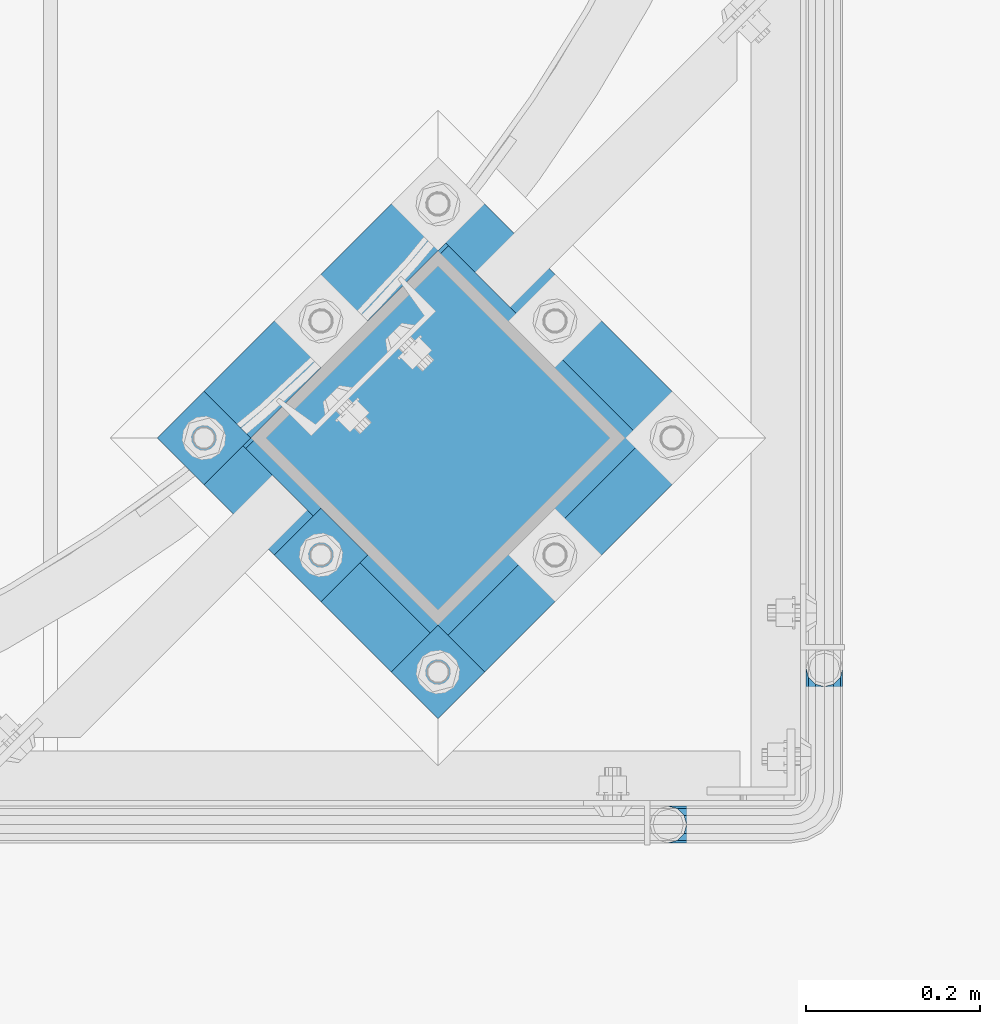
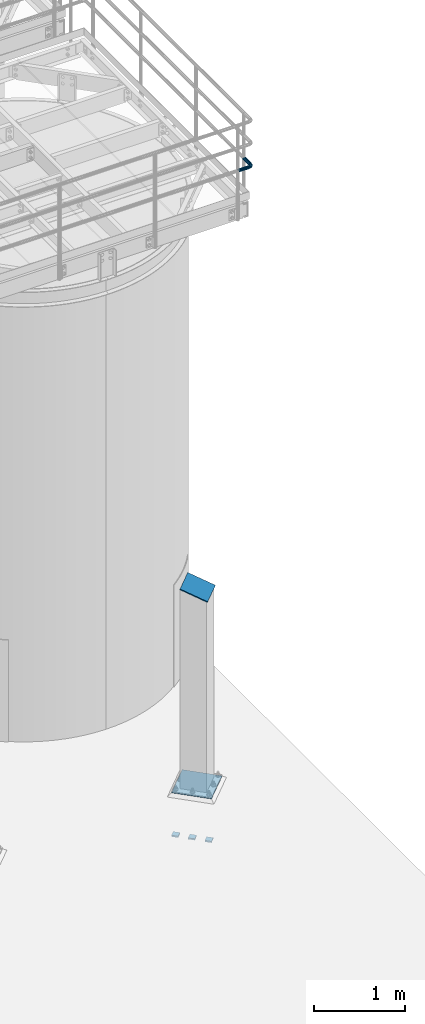
# One storey, part 1101 of 1876: 5 beams, 1 member, 3 elements without a shape of their own.
"""IFC2X3 building model written with IfcOpenShell, lengths in millimetres."""

import ifcopenshell
import ifcopenshell.guid

model = None  # the IFC model being written
_history = None  # IfcOwnerHistory: only IFC2X3 demands one
_inside = {}  # id of a spatial element -> (the spatial element, [elements in it])
_under = {}  # id of a project, library or spatial element -> (it, [spatial elements below it])
_declared = {}  # id of a project -> (the project, [libraries it declares])
_typed = {}  # id of a type object -> (the type object, [elements of that type])
_made_of = {}  # id of a material, layer set ... -> (it, [elements and type objects made of it])


def new_model(schema):
    """Start an empty IFC model of exactly this schema.

    Asked for "IFC4X3", IfcOpenShell would pick the latest addendum, in which some entities
    have other attributes; the version numbers below select the first issue.
    IFC2X3 requires an IfcOwnerHistory on every rooted entity: one is made here for all.
    """
    global model, _history
    if schema == "IFC4X3":
        model = ifcopenshell.file(schema_version=(4, 3, 0, 0))
    else:
        model = ifcopenshell.file(schema=schema)
    _inside.clear()
    _under.clear()
    _declared.clear()
    _typed.clear()
    _made_of.clear()
    _history = None
    if model.schema == "IFC2X3":
        org = make("IfcOrganization", Name="unknown")
        user = make(
            "IfcPersonAndOrganization",
            ThePerson=make("IfcPerson", FamilyName="unknown"),
            TheOrganization=org,
        )
        app = make(
            "IfcApplication",
            ApplicationDeveloper=org,
            Version="unknown",
            ApplicationFullName="unknown",
            ApplicationIdentifier="unknown",
        )
        _history = make(
            "IfcOwnerHistory",
            OwningUser=user,
            OwningApplication=app,
            ChangeAction="ADDED",
            CreationDate=0,
        )
    return model


def make(cls, **values):
    """One entity of the class cls with the attributes given. An attribute that is None is left unset."""
    return model.create_entity(
        cls, **{name: value for name, value in values.items() if value is not None}
    )


def rooted(cls, **values):
    """An entity with a GlobalId (a new one), such as an element, a storey or a relation."""
    return make(cls, GlobalId=ifcopenshell.guid.new(), OwnerHistory=_history, **values)


def si_unit(unit_type, name, prefix=None):
    """IfcSIUnit, for example si_unit("LENGTHUNIT", "METRE", prefix="MILLI")."""
    return make("IfcSIUnit", UnitType=unit_type, Prefix=prefix, Name=name)


def assignment(units):
    """IfcUnitAssignment: the units of a project."""
    return None if units is None else make("IfcUnitAssignment", Units=units)


def point(xyz):
    """IfcCartesianPoint."""
    return None if xyz is None else make("IfcCartesianPoint", Coordinates=xyz)


def direction(xyz):
    """IfcDirection."""
    return None if xyz is None else make("IfcDirection", DirectionRatios=xyz)


def frame(location, z_axis=None, x_axis=None):
    """IfcAxis2Placement3D, a coordinate frame: its origin and axes. An axis left out is left unset."""
    return make(
        "IfcAxis2Placement3D",
        Location=point(location),
        Axis=direction(z_axis),
        RefDirection=direction(x_axis),
    )


def origin_with_axes():
    """The frame at (0, 0, 0) with the z axis (0, 0, 1) and the x axis (1, 0, 0) written out."""
    return frame((0.0, 0.0, 0.0), z_axis=(0.0, 0.0, 1.0), x_axis=(1.0, 0.0, 0.0))


def place(relative_to, where):
    """IfcLocalPlacement: puts the frame where relative to a parent placement (None: the world)."""
    return make(
        "IfcLocalPlacement", PlacementRelTo=relative_to, RelativePlacement=where
    )


def context(
    kind, dimensions, precision=None, world=None, true_north=None, identifier=None
):
    """IfcGeometricRepresentationContext, for example the 3D "Model" context."""
    return make(
        "IfcGeometricRepresentationContext",
        ContextIdentifier=identifier,
        ContextType=kind,
        CoordinateSpaceDimension=dimensions,
        Precision=precision,
        WorldCoordinateSystem=world,
        TrueNorth=true_north,
    )


def subcontext(parent, identifier, kind, view, scale=None):
    """IfcGeometricRepresentationSubContext, for example "Body" below "Model"."""
    return make(
        "IfcGeometricRepresentationSubContext",
        ContextIdentifier=identifier,
        ContextType=kind,
        ParentContext=parent,
        TargetScale=scale,
        TargetView=view,
    )


def project(units=None, contexts=None):
    """IfcProject with its units and contexts."""
    return rooted(
        "IfcProject",
        Name="project",
        RepresentationContexts=contexts,
        UnitsInContext=assignment(units),
    )


def spatial(cls, under=None, at=None, **own):
    """A site, building, storey or space (cls), placed at a placement, below another one or the project."""
    s = rooted(cls, ObjectPlacement=at, **own)
    if under is not None:
        _under.setdefault(under.id(), (under, []))[1].append(s)
    return s


def faces_of(points, faces, orient=None, outer=None):
    """IfcFace entities. A face is a list of loops; a loop is a list of indices into points, from 0.

    orient and outer hold one flag for each loop. By default every Orientation is true, the
    first loop of a face is its IfcFaceOuterBound and the others are IfcFaceBound.
    """
    made = []
    for i, loops in enumerate(faces):
        bounds = []
        for j, loop in enumerate(loops):
            is_outer = j == 0 if outer is None else outer[i][j]
            bounds.append(
                make(
                    "IfcFaceOuterBound" if is_outer else "IfcFaceBound",
                    Bound=make("IfcPolyLoop", Polygon=[points[k] for k in loop]),
                    Orientation=True if orient is None else orient[i][j],
                )
            )
        made.append(make("IfcFace", Bounds=bounds))
    return made


def faceted_brep(points, faces, orient=None, outer=None, voids=None):
    """IfcFacetedBrep: a solid bounded by flat faces; with voids (closed shells), ...WithVoids."""
    shared = [point(p) for p in points]
    hull = make("IfcClosedShell", CfsFaces=faces_of(shared, faces, orient, outer))
    if voids is None:
        return make("IfcFacetedBrep", Outer=hull)
    return make(
        "IfcFacetedBrepWithVoids",
        Outer=hull,
        Voids=[
            make(cls, CfsFaces=faces_of(shared, fs, o, b)) for cls, fs, o, b in voids
        ],
    )


def shape(context_of_items, identifier, shape_type, items):
    """IfcShapeRepresentation: the items that make up one representation, for example the "Body"."""
    return make(
        "IfcShapeRepresentation",
        ContextOfItems=context_of_items,
        RepresentationIdentifier=identifier,
        RepresentationType=shape_type,
        Items=items,
    )


def material(Name=None, Category=None):
    """IfcMaterial."""
    return make("IfcMaterial", Name=Name, Category=Category)


def made_of(thing, what):
    """Note that an element or type object is made of a material, layer set ...; save() writes the relation."""
    if what is not None:
        _made_of.setdefault(what.id(), (what, []))[1].append(thing)
    return thing


def type_object(cls, material=None, **own):
    """A type object (cls), such as IfcWallType, which elements share."""
    return made_of(rooted(cls, **own), material)


def element(
    cls,
    number,
    at=None,
    inside=None,
    cuts=None,
    type_object=None,
    material=None,
    context=None,
    identifier="Body",
    shape_type=None,
    held_by="IfcProductDefinitionShape",
    body=None,
    shapes=None,
    **own,
):
    """One element of the class cls, such as IfcWall. Its Tag is "e" and its number.

    at: its placement. inside: the storey or other place that contains it. cuts: it is an
    opening in that element (IfcRelVoidsElement). A single representation is given by context,
    identifier, shape_type and body (its items); several are given by shapes. held_by: the class
    of the entity that holds the representations. save() writes the other relations.
    """
    e = rooted(cls, Tag="e%d" % number, ObjectPlacement=at, **own)
    if body is not None:
        shapes = [shape(context, identifier, shape_type, body)]
    if shapes is not None:
        e.Representation = make(held_by, Representations=shapes)
    if inside is not None:
        _inside.setdefault(inside.id(), (inside, []))[1].append(e)
    if cuts is not None:
        rooted(
            "IfcRelVoidsElement", RelatingBuildingElement=cuts, RelatedOpeningElement=e
        )
    if type_object is not None:
        _typed.setdefault(type_object.id(), (type_object, []))[1].append(e)
    return made_of(e, material)


def aggregate(whole, parts):
    """IfcRelAggregates: a whole, such as a stair, and the parts it consists of."""
    return rooted("IfcRelAggregates", RelatingObject=whole, RelatedObjects=parts)


def save(model, path):
    """Write the relations noted so far, then the file.

    IfcRelAggregates (storeys below a building ...), IfcRelContainedInSpatialStructure (elements
    in a storey), IfcRelDefinesByType, IfcRelAssociatesMaterial and IfcRelDeclares: one each for
    every whole, place, type object, material and project.
    """
    for whole, parts in _under.values():
        aggregate(whole, parts)
    for where, things in _inside.values():
        rooted(
            "IfcRelContainedInSpatialStructure",
            RelatedElements=things,
            RelatingStructure=where,
        )
    for kind, things in _typed.values():
        rooted("IfcRelDefinesByType", RelatedObjects=things, RelatingType=kind)
    for what, things in _made_of.values():
        rooted("IfcRelAssociatesMaterial", RelatedObjects=things, RelatingMaterial=what)
    for by, libraries in _declared.values():
        rooted("IfcRelDeclares", RelatingContext=by, RelatedDefinitions=libraries)
    model.write(path)


model = new_model("IFC2X3")

# Units and contexts
model_context = context("Model", 3, precision=1e-05, world=origin_with_axes())
body_context = subcontext(model_context, "Body", "Model", "MODEL_VIEW")
ifc_project = project(units=[si_unit("LENGTHUNIT", "METRE", prefix="MILLI"), si_unit("AREAUNIT", "SQUARE_METRE"), si_unit("VOLUMEUNIT", "CUBIC_METRE"), si_unit("MASSUNIT", "GRAM", prefix="KILO"), si_unit("TIMEUNIT", "SECOND"), si_unit("PLANEANGLEUNIT", "RADIAN"), si_unit("SOLIDANGLEUNIT", "STERADIAN"), si_unit("THERMODYNAMICTEMPERATUREUNIT", "DEGREE_CELSIUS"), si_unit("LUMINOUSINTENSITYUNIT", "LUMEN")], contexts=[model_context])

# Site, building, storey
site_placement = place(None, origin_with_axes())
site = spatial("IfcSite", under=ifc_project, at=site_placement, CompositionType="ELEMENT")
building_placement = place(site_placement, origin_with_axes())
building = spatial("IfcBuilding", under=site, at=building_placement, Name="Undefined", CompositionType="ELEMENT")
storey_placement = place(building_placement, origin_with_axes())
storey = spatial("IfcBuildingStorey", under=building, at=storey_placement, Name="Undefined", CompositionType="ELEMENT", Elevation=0.0)

# Assembly, beam
assembly_1_placement = place(storey_placement, origin_with_axes())
assembly_1 = element("IfcElementAssembly", 1, at=assembly_1_placement, inside=storey, Name="HANDRAIL", AssemblyPlace="NOTDEFINED", PredefinedType="RIGID_FRAME")
ifc_material_1 = material()
beam_type_1 = type_object("IfcBeamType", Name="PIPE1-1/4STD", PredefinedType="NOTDEFINED")
beam_1_placement = place(assembly_1_placement, frame((6845.30143150122, -15432.4964042969, 8480.425), z_axis=(0.0, 0.0, -1.0), x_axis=(1.0, 0.0, 0.0)))
beam_1 = element("IfcBeam", 2, at=beam_1_placement, type_object=beam_type_1, material=ifc_material_1, Name="HANDRAIL", ObjectType="PIPE1-1/4STD", context=body_context, shape_type="Brep", body=[
    faceted_brep([(158.747132080079, -179.832000732422, 1.81898940354586e-12), (161.571584517495, -169.290999999999, -10.5409999999974), (161.571584517495, -169.290999999999, 10.5410000000029), (188.592132080079, -161.098037455637, -15.1779612267237), (179.829132080079, -158.749999999998, -17.525999999998), (179.829132080079, -158.749999999998, -21.0819999999985), (190.370132080079, -161.574452437415, -18.2575475625817), (190.370136997563, -161.574452437415, -13.3999563092402), (171.066132080079, -161.098040090908, -15.1779612267237), (169.288136997563, -161.574452437415, -13.3999661442085), (169.288132080079, -161.574452437415, -18.2575475625817), (164.651170853354, -166.211418581624, -8.76299999999719), (162.303132080079, -168.559457354899, 1.81898940354586e-12), (164.651170853354, -166.211418581624, 8.76300000000265), (169.288136997563, -161.574452437415, 13.3999661442122), (169.288132080079, -161.574452437415, 18.2575475625854), (171.066132080079, -161.098040090908, 15.1779612267292), (179.829132080079, -158.749999999998, 17.5260000000017), (179.829132080079, -158.749999999998, 21.0820000000022), (188.592132080079, -161.098037455637, 15.1779612267292), (190.370136997563, -161.574452437415, 13.3999563092439), (190.370132080079, -161.574452437415, 18.2575475625854), (200.911136997564, -179.831999999999, 1.81898940354586e-12), (198.086679642663, -169.290999999999, 10.5410000000029), (198.086679642663, -169.290999999999, -10.5409999999974), (195.007093306805, -166.211408746656, 8.76300000000265), (197.355132080079, -168.55944751993, 1.81898940354586e-12), (195.007093306805, -166.211408746656, -8.76299999999719), (141.729133605959, 21.0819999999967, 3.63797880709171e-12), (141.72913360596, 18.2575475625799, -10.5409999999956), (10.5409999957128, 18.2575475579433, -10.5409999999993), (9.09494701772928e-13, 21.0820000000003, 0.0), (10.5409999999983, 18.2575475625836, 10.5410000000011), (141.729133605959, 18.2575475625799, 10.5410000000047), (141.729133605959, 10.5409999999974, 18.2575475625872), (18.2575475625817, 10.5409999999993, 18.2575475625836), (141.729133605958, -3.63797880709171e-12, 21.082000000004), (21.0819999999985, 1.81898940354586e-12, 21.0820000000003), (141.729133605958, -21.0820000000022, 3.63797880709171e-12), (141.729133605959, -18.2575475625872, -10.5409999999956), (147.860788147674, -19.2287062354389, -10.5409999999956), (146.987984344709, -21.9149201310101, 3.63797880709171e-12), (141.729133605958, -18.2575475625872, 10.5410000000047), (147.860788147674, -19.2287062354389, 10.5410000000047), (141.729133605958, -10.5410000000029, 18.2575475625872), (150.245332482414, -11.8898333927427, 18.2575475625872), (153.50268062012, -1.86474665447531, 21.082000000004), (156.760028757826, 8.16034008379211, 18.257547562589), (159.144573092567, 15.4992129264883, 10.5410000000047), (160.017376895533, 18.1854268220595, 5.45696821063757e-12), (159.144573092567, 15.4992129264883, -10.5409999999956), (141.72913360596, 10.5409999999974, -18.2575475625799), (156.760028757827, 8.16034008379211, -18.2575475625781), (141.729133605959, -3.63797880709171e-12, -21.0819999999949), (153.502680620121, -1.86474665447531, -21.0819999999949), (141.729133605959, -10.5410000000029, -18.2575475625799), (150.245332482415, -11.8898333927427, -18.2575475625781), (190.370132080081, -38.0999984741229, -18.2575475625781), (198.086679642664, -38.0999984741247, -10.5409999999956), (179.829132080081, -38.0999984741229, -21.0819999999949), (169.288132080081, -38.0999984741247, -18.2575475625781), (161.571584517497, -38.0999984741247, -10.5409999999956), (158.747132080079, -38.0999984741247, 5.45696821063757e-12), (161.571584517496, -38.0999984741247, 10.5410000000047), (169.28813208008, -38.0999984741247, 18.257547562589), (179.82913208008, -38.0999984741247, 21.082000000004), (190.37013208008, -38.0999984741247, 18.257547562589), (198.086679642664, -38.0999984741247, 10.5410000000047), (200.91113208008, -38.0999984741247, 5.45696821063757e-12), (198.014558902142, -19.8117551845498, 5.45696821063757e-12), (195.328345006572, -20.6845589875156, -10.5409999999938), (195.328345006572, -20.6845589875156, 10.5410000000047), (187.989472163875, -23.0691033222574, 18.257547562589), (177.964385425607, -26.3264514599632, 21.0820000000058), (167.93929868734, -29.583799597669, 18.257547562589), (160.600425844644, -31.968343932409, 10.5410000000047), (157.914211949073, -32.8411477353748, 5.45696821063757e-12), (160.600425844644, -31.968343932409, -10.5409999999956), (167.939298687341, -29.583799597669, -18.2575475625781), (177.964385425608, -26.3264514599614, -21.0819999999949), (187.989472163876, -23.0691033222556, -18.2575475625781), (187.323346110924, -4.97386405835823, -10.5409999999938), (181.080527994891, -9.50953691425821, -18.2575475625781), (189.608376132597, -3.31369256984362, 5.45696821063757e-12), (187.323346110923, -4.97386405835823, 10.5410000000047), (181.08052799489, -9.50953691425821, 18.257547562589), (172.552679857184, -15.7053812586728, 21.0820000000058), (164.024831719476, -21.9012256030874, 18.257547562589), (157.782013603444, -26.4368984589855, 10.5410000000047), (155.49698358177, -28.0970699475001, 5.45696821063757e-12), (157.782013603444, -26.4368984589855, -10.5409999999956), (164.024831719477, -21.9012256030855, -18.2575475625781), (172.552679857185, -15.705381258671, -21.0819999999949), (170.319595165825, 1.25139591480729, -18.2575475625781), (164.123750821412, -7.27645222289902, -21.0819999999949), (174.855268021725, 7.49421403083943, -10.5409999999956), (176.51543951024, 9.7792440525136, 5.45696821063757e-12), (174.855268021724, 7.49421403083943, 10.5410000000047), (170.319595165825, 1.25139591480729, 18.257547562589), (164.123750821411, -7.27645222289902, 21.0820000000058), (157.927906476996, -15.8043003606053, 18.257547562589), (153.392233621096, -22.0471184766393, 10.5410000000047), (151.732062132583, -24.3321484983135, 3.63797880709171e-12), (153.392233621097, -22.0471184766393, -10.5409999999956), (157.927906476997, -15.8043003606053, -18.2575475625781), (10.5409999957128, -18.2575475672238, -10.5409999999993), (18.2575475625817, -10.5410000000011, -18.2575475625836), (21.0819999999985, 0.0, -21.0819999999985), (18.2575475625817, 10.5409999999993, -18.2575475625836), (141.72913360596, 8.76299999999719, -15.1779612267219), (141.72913360596, 15.1779612267237, -8.76299999999537), (13.6205863358573, 15.1779612267255, -8.76299999999901), (18.2575475625817, 10.5410000000011, -13.3999612267235), (18.7339612267251, 8.76299999999901, -15.1779612267255), (141.729133605959, 17.525999999998, 3.63797880709171e-12), (11.2725475625839, 17.5259999999998, 0.0), (13.6205863358573, 15.1779612267255, 8.76300000000083), (18.2575475625817, 10.5410000000011, 13.3999612267253), (141.729133605959, 15.1779612267237, 8.76300000000447), (141.729133605959, 8.76299999999719, 15.177961226731), (18.7339612267251, 8.76299999999901, 15.1779612267273), (21.0819999999985, 1.81898940354586e-12, 17.5259999999998), (141.729133605958, -3.63797880709171e-12, 17.5260000000035), (141.729133605958, -8.76300000000265, 15.177961226731), (18.7339612267233, -8.76300000000083, 15.1779612267273), (141.729133605958, -15.1779612267292, 8.76300000000447), (141.729133605958, -17.5260000000035, 3.63797880709171e-12), (11.2725475625793, -17.5259999999998, 0.0), (13.6205863358537, -15.1779612267255, 8.76300000000083), (18.2575475625817, -10.5409999999974, 13.3999612267289), (18.2575475625817, -10.5410000000011, 18.2575475625836), (10.5409999999983, -18.2575475625836, 10.5410000000011), (9.09494701772928e-13, -21.0820000000003, 0.0), (13.6205863358537, -15.1779612267255, -8.76299999999901), (18.2575475625817, -10.5409999999974, -13.3999612267271), (141.729133605959, -15.1779612267292, -8.76299999999537), (141.729133605959, -8.76300000000265, -15.1779612267219), (141.729133605959, -3.63797880709171e-12, -17.5259999999962), (21.0819999999985, 0.0, -17.5259999999998), (18.7339612267233, -8.76300000000083, -15.1779612267255), (153.502680620121, -1.86474665447531, -17.5259999999962), (156.210596541829, 6.46936159781944, -15.1779612267219), (158.192928579143, 12.570352274277, -8.76299999999537), (158.918512463535, 14.8034698501142, 5.45696821063757e-12), (158.192928579142, 12.570352274277, 8.76300000000447), (156.210596541828, 6.46936159781944, 15.177961226731), (153.50268062012, -1.86474665447531, 17.5260000000053), (150.794764698413, -10.1988549067701, 15.177961226731), (148.812432661099, -16.2998455832294, 8.76300000000447), (148.086848776706, -18.5329631590648, 3.63797880709171e-12), (148.812432661099, -16.2998455832294, -8.76299999999537), (150.794764698413, -10.1988549067701, -15.1779612267219), (158.972988655572, -14.3658681446068, -15.1779612267219), (164.123750821412, -7.27645222289902, -17.5259999999944), (155.202369052476, -19.5556807952853, -8.76299999999537), (153.822226489734, -21.4552840663146, 5.45696821063757e-12), (155.202369052475, -19.5556807952853, 8.76300000000447), (158.972988655572, -14.3658681446068, 15.177961226731), (164.123750821411, -7.27645222289902, 17.5260000000053), (169.274512987249, -0.187036301191256, 15.177961226731), (173.045132590347, 5.00277634948725, 8.76300000000447), (174.425275153088, 6.90237962051651, 5.45696821063757e-12), (173.045132590347, 5.00277634948725, -8.76299999999537), (169.27451298725, -0.187036301191256, -15.1779612267219), (172.552679857184, -15.705381258671, -17.5259999999944), (179.642095778892, -10.5546190928326, -15.1779612267201), (165.463263935476, -20.8561434245112, -15.1779612267219), (160.273451284798, -24.626763027607, -8.76299999999537), (158.373848013768, -26.0069055903496, 5.45696821063757e-12), (160.273451284797, -24.6267630276088, 8.76300000000447), (165.463263935476, -20.8561434245112, 15.177961226731), (172.552679857184, -15.7053812586728, 17.5260000000053), (179.642095778891, -10.5546190928344, 15.177961226731), (184.83190842957, -6.78399948973674, 8.76300000000447), (186.7315117006, -5.40385692699419, 5.45696821063757e-12), (184.83190842957, -6.78399948973674, -8.76299999999537), (186.298493677902, -23.6185355382549, -15.1779612267201), (192.399484354361, -21.6362035009406, -8.76299999999537), (177.964385425608, -26.3264514599614, -17.5259999999944), (169.630277173314, -29.0343673816697, -15.1779612267219), (163.529286496855, -31.016699418984, -8.76299999999537), (161.296168921019, -31.7422833033779, 5.45696821063757e-12), (163.529286496854, -31.016699418984, 8.76300000000447), (169.630277173313, -29.0343673816697, 15.177961226731), (177.964385425607, -26.3264514599632, 17.5260000000053), (186.298493677902, -23.6185355382549, 15.177961226731), (192.399484354361, -21.6362035009406, 8.76300000000447), (194.632601930197, -20.9106196165467, 5.45696821063757e-12), (195.007093306806, -38.0999984741247, -8.76299999999537), (197.355132080081, -38.0999984741247, 5.45696821063757e-12), (188.592132080081, -38.0999984741229, -15.1779612267219), (179.829132080081, -38.0999984741229, -17.5259999999944), (171.066132080081, -38.0999984741247, -15.1779612267219), (164.651170853354, -38.0999984741247, -8.76299999999537), (162.303132080079, -38.0999984741247, 5.45696821063757e-12), (164.651170853354, -38.0999984741247, 8.76300000000447), (171.06613208008, -38.0999984741247, 15.177961226731), (179.82913208008, -38.0999984741247, 17.5260000000053), (188.59213208008, -38.0999984741247, 15.177961226731), (195.007093306806, -38.0999984741247, 8.76300000000447)], [[[0, 1, 2]], [[3, 4, 5, 6, 7]], [[8, 9, 10, 5, 4]], [[2, 1, 10, 9, 11, 12, 13, 14, 15]], [[15, 14, 16, 17, 18]], [[18, 17, 19, 20, 21]], [[22, 23, 24]], [[21, 20, 25, 26, 27, 7, 6, 24, 23]], [[28, 29, 30, 31]], [[31, 30, 32]], [[33, 28, 31, 32]], [[34, 33, 32, 35]], [[36, 34, 35, 37]], [[38, 39, 40, 41]], [[42, 38, 41, 43]], [[44, 42, 43, 45]], [[36, 44, 45, 46]], [[34, 36, 46, 47]], [[33, 34, 47, 48]], [[28, 33, 48, 49]], [[29, 28, 49, 50]], [[51, 29, 50, 52]], [[53, 51, 52, 54]], [[55, 53, 54, 56]], [[57, 58, 24, 6]], [[59, 57, 6, 5]], [[60, 59, 5, 10]], [[61, 60, 10, 1]], [[62, 61, 1, 0]], [[63, 62, 0, 2]], [[64, 63, 2, 15]], [[65, 64, 15, 18]], [[66, 65, 18, 21]], [[67, 66, 21, 23]], [[68, 67, 23, 22]], [[58, 68, 22, 24]], [[69, 68, 58, 70]], [[71, 67, 68, 69]], [[72, 66, 67, 71]], [[73, 65, 66, 72]], [[74, 64, 65, 73]], [[75, 63, 64, 74]], [[76, 62, 63, 75]], [[77, 61, 62, 76]], [[78, 60, 61, 77]], [[79, 59, 60, 78]], [[80, 57, 59, 79]], [[70, 58, 57, 80]], [[81, 70, 80, 82]], [[83, 69, 70, 81]], [[84, 71, 69, 83]], [[85, 72, 71, 84]], [[86, 73, 72, 85]], [[87, 74, 73, 86]], [[88, 75, 74, 87]], [[89, 76, 75, 88]], [[90, 77, 76, 89]], [[91, 78, 77, 90]], [[92, 79, 78, 91]], [[82, 80, 79, 92]], [[93, 82, 92, 94]], [[95, 81, 82, 93]], [[96, 83, 81, 95]], [[97, 84, 83, 96]], [[98, 85, 84, 97]], [[99, 86, 85, 98]], [[100, 87, 86, 99]], [[101, 88, 87, 100]], [[102, 89, 88, 101]], [[103, 90, 89, 102]], [[104, 91, 90, 103]], [[94, 92, 91, 104]], [[54, 94, 104, 56]], [[52, 93, 94, 54]], [[50, 95, 93, 52]], [[49, 96, 95, 50]], [[48, 97, 96, 49]], [[47, 98, 97, 48]], [[46, 99, 98, 47]], [[45, 100, 99, 46]], [[43, 101, 100, 45]], [[41, 102, 101, 43]], [[40, 103, 102, 41]], [[56, 104, 103, 40]], [[39, 55, 56, 40]], [[55, 39, 105, 106]], [[53, 55, 106, 107]], [[51, 53, 107, 108]], [[29, 51, 108, 30]], [[109, 110, 111, 112, 113]], [[110, 114, 115, 111]], [[32, 30, 108, 112, 111, 115, 116, 117, 35]], [[114, 118, 116, 115]], [[116, 118, 119, 120, 117]], [[35, 117, 120, 121, 37]], [[119, 122, 121, 120]], [[122, 123, 124, 121]], [[125, 126, 127, 128]], [[123, 125, 128, 129, 124]], [[37, 121, 124, 129, 130]], [[44, 36, 37, 130]], [[42, 44, 130, 131]], [[38, 42, 131, 132]], [[39, 38, 132, 105]], [[131, 105, 132]], [[130, 129, 128, 127, 133, 134, 106, 105, 131]], [[126, 135, 133, 127]], [[136, 137, 138, 139]], [[133, 135, 136, 139, 134]], [[138, 107, 106, 134, 139]], [[113, 112, 108, 107, 138]], [[137, 109, 113, 138]], [[109, 137, 140, 141]], [[110, 109, 141, 142]], [[114, 110, 142, 143]], [[118, 114, 143, 144]], [[119, 118, 144, 145]], [[122, 119, 145, 146]], [[123, 122, 146, 147]], [[125, 123, 147, 148]], [[126, 125, 148, 149]], [[135, 126, 149, 150]], [[136, 135, 150, 151]], [[137, 136, 151, 140]], [[151, 152, 153, 140]], [[150, 154, 152, 151]], [[149, 155, 154, 150]], [[148, 156, 155, 149]], [[147, 157, 156, 148]], [[146, 158, 157, 147]], [[145, 159, 158, 146]], [[144, 160, 159, 145]], [[143, 161, 160, 144]], [[142, 162, 161, 143]], [[141, 163, 162, 142]], [[140, 153, 163, 141]], [[153, 164, 165, 163]], [[152, 166, 164, 153]], [[154, 167, 166, 152]], [[155, 168, 167, 154]], [[156, 169, 168, 155]], [[157, 170, 169, 156]], [[158, 171, 170, 157]], [[159, 172, 171, 158]], [[160, 173, 172, 159]], [[161, 174, 173, 160]], [[162, 175, 174, 161]], [[163, 165, 175, 162]], [[165, 176, 177, 175]], [[164, 178, 176, 165]], [[166, 179, 178, 164]], [[167, 180, 179, 166]], [[168, 181, 180, 167]], [[169, 182, 181, 168]], [[170, 183, 182, 169]], [[171, 184, 183, 170]], [[172, 185, 184, 171]], [[173, 186, 185, 172]], [[174, 187, 186, 173]], [[175, 177, 187, 174]], [[177, 188, 189, 187]], [[176, 190, 188, 177]], [[178, 191, 190, 176]], [[179, 192, 191, 178]], [[180, 193, 192, 179]], [[181, 194, 193, 180]], [[182, 195, 194, 181]], [[183, 196, 195, 182]], [[184, 197, 196, 183]], [[185, 198, 197, 184]], [[186, 199, 198, 185]], [[187, 189, 199, 186]], [[199, 189, 26, 25]], [[19, 198, 199, 25, 20]], [[197, 198, 19, 17]], [[196, 197, 17, 16]], [[13, 195, 196, 16, 14]], [[194, 195, 13, 12]], [[193, 194, 12, 11]], [[192, 193, 11, 9, 8]], [[191, 192, 8, 4]], [[190, 191, 4, 3]], [[188, 190, 3, 7, 27]], [[189, 188, 27, 26]]]),
])
aggregate(assembly_1, [beam_1])

# Assembly, member
assembly_2_placement = place(storey_placement, origin_with_axes())
assembly_2 = element("IfcElementAssembly", 3, at=assembly_2_placement, inside=storey, Name="COLUMN", AssemblyPlace="NOTDEFINED", PredefinedType="RIGID_FRAME")
ifc_material_2 = material(Name="STEEL/A36")
member_type = type_object("IfcMemberType", PredefinedType="NOTDEFINED")
member_placement = place(assembly_2_placement, frame((6474.04753164663, -14881.305031196, 2749.16704824061), z_axis=(-0.707106781186547, -0.707106781186548, 0.0), x_axis=(0.664463024761457, -0.664463024761457, -0.342020141877214)))
member = element("IfcMember", 4, at=member_placement, type_object=member_type, material=ifc_material_2, Name="PLATE", context=body_context, shape_type="Brep", body=[
    faceted_brep([(0.0, 6.35000000000042, -165.100000000026), (0.0, 6.35000000000042, 165.100000000029), (337.061384869998, 6.34999999999997, 165.099999999921), (337.061384869996, 6.34999999999997, -165.100000000135), (1.81898940354586e-12, -6.34999999999849, 165.100000000029), (337.061384869998, -6.3499999999994, 165.099999999921), (0.0, -6.34999999999894, -165.100000000026), (337.061384869998, -6.3499999999994, -165.100000000136)], [[[0, 1, 2, 3]], [[1, 4, 5, 2]], [[4, 6, 7, 5]], [[6, 0, 3, 7]], [[5, 7, 3, 2]], [[6, 4, 1, 0]]]),
])
aggregate(assembly_2, [member])

# Assembly, beams
assembly_3_placement = place(storey_placement, origin_with_axes())
assembly_3 = element("IfcElementAssembly", 5, at=assembly_3_placement, inside=storey, Name="TEMPLATE", AssemblyPlace="NOTDEFINED", PredefinedType="RIGID_FRAME")
beam_type_2 = type_object("IfcBeamType", PredefinedType="NOTDEFINED")
beam_2_placement = place(assembly_3_placement, frame((6607.21565921985, -15229.9993056794, -542.925), z_axis=(-0.707106781186548, 0.707106781186547, 0.0), x_axis=(-0.707106781186547, -0.707106781186548, 0.0)))
beam_2 = element("IfcBeam", 6, at=beam_2_placement, type_object=beam_type_2, material=ifc_material_2, Name="PLATE", context=body_context, shape_type="Brep", body=[
    faceted_brep([(0.0, 9.52499999999998, -38.1000000000058), (-9.09494701772928e-13, 9.52499999999998, 38.1000000000076), (76.2000000000762, 9.52499999999998, 38.1000000000058), (76.2000000000762, 9.52499999999998, -38.1000000000058), (-9.09494701772928e-13, -9.52499999999998, 38.1000000000076), (76.2000000000762, -9.52499999999998, 38.1000000000058), (0.0, -9.52499999999998, -38.1000000000058), (76.2000000000762, -9.52499999999998, -38.1000000000058)], [[[0, 1, 2, 3]], [[1, 4, 5, 2]], [[4, 6, 7, 5]], [[6, 0, 3, 7]], [[5, 7, 3, 2]], [[6, 4, 1, 0]]]),
])
beam_3_placement = place(assembly_3_placement, frame((6472.5118174037, -15095.2954638633, -542.925), z_axis=(-0.707106781186548, 0.707106781186547, 0.0), x_axis=(-0.707106781186547, -0.707106781186548, 0.0)))
beam_3 = element("IfcBeam", 7, at=beam_3_placement, type_object=beam_type_2, material=ifc_material_2, Name="PLATE", context=body_context, shape_type="Brep", body=[
    faceted_brep([(0.0, 9.52499999999998, -38.1000000000058), (-9.09494701772928e-13, 9.52499999999998, 38.1000000000076), (76.2000000000762, 9.52499999999998, 38.1000000000058), (76.2000000000762, 9.52499999999998, -38.1000000000058), (-9.09494701772928e-13, -9.52499999999998, 38.1000000000076), (76.2000000000762, -9.52499999999998, 38.1000000000058), (0.0, -9.52499999999998, -38.1000000000058), (76.2000000000762, -9.52499999999998, -38.1000000000058)], [[[0, 1, 2, 3]], [[1, 4, 5, 2]], [[4, 6, 7, 5]], [[6, 0, 3, 7]], [[5, 7, 3, 2]], [[6, 4, 1, 0]]]),
])
beam_4_placement = place(assembly_3_placement, frame((6337.80797558755, -14960.5916220471, -542.925), z_axis=(-0.707106781186548, 0.707106781186547, 0.0), x_axis=(-0.707106781186547, -0.707106781186548, 0.0)))
beam_4 = element("IfcBeam", 8, at=beam_4_placement, type_object=beam_type_2, material=ifc_material_2, Name="PLATE", context=body_context, shape_type="Brep", body=[
    faceted_brep([(0.0, 9.52499999999998, -38.1000000000058), (-9.09494701772928e-13, 9.52499999999998, 38.1000000000076), (76.2000000000762, 9.52499999999998, 38.1000000000058), (76.2000000000762, 9.52499999999998, -38.1000000000058), (-9.09494701772928e-13, -9.52499999999998, 38.1000000000076), (76.2000000000762, -9.52499999999998, 38.1000000000058), (0.0, -9.52499999999998, -38.1000000000058), (76.2000000000762, -9.52499999999998, -38.1000000000058)], [[[0, 1, 2, 3]], [[1, 4, 5, 2]], [[4, 6, 7, 5]], [[6, 0, 3, 7]], [[5, 7, 3, 2]], [[6, 4, 1, 0]]]),
])
beam_type_3 = type_object("IfcBeamType", PredefinedType="NOTDEFINED")
beam_5_placement = place(assembly_3_placement, frame((6741.91950103587, -14825.8877802309, 40.4815), z_axis=(0.707106781186547, -0.707106781186548, 0.0), x_axis=(-0.707106781186547, -0.707106781186548, 0.0)))
beam_5 = element("IfcBeam", 9, at=beam_5_placement, type_object=beam_type_3, material=ifc_material_2, Name="TEMPLATE", context=body_context, shape_type="Brep", body=[
    faceted_brep([(9.09494701772928e-13, 2.3815, -228.600000000035), (-9.09494701772928e-13, 2.3815, 228.60000000004), (457.200000000363, 2.3815, 228.60000000004), (457.200000000362, 2.3815, -228.600000000037), (-9.09494701772928e-13, -2.3815, 228.60000000004), (457.200000000363, -2.3815, 228.60000000004), (9.09494701772928e-13, -2.3815, -228.600000000035), (457.200000000362, -2.3815, -228.600000000037)], [[[0, 1, 2, 3]], [[1, 4, 5, 2]], [[4, 6, 7, 5]], [[6, 0, 3, 7]], [[5, 7, 3, 2]], [[6, 4, 1, 0]]]),
])
aggregate(assembly_3, [beam_2, beam_3, beam_4, beam_5])

save(model, "model.ifc")
